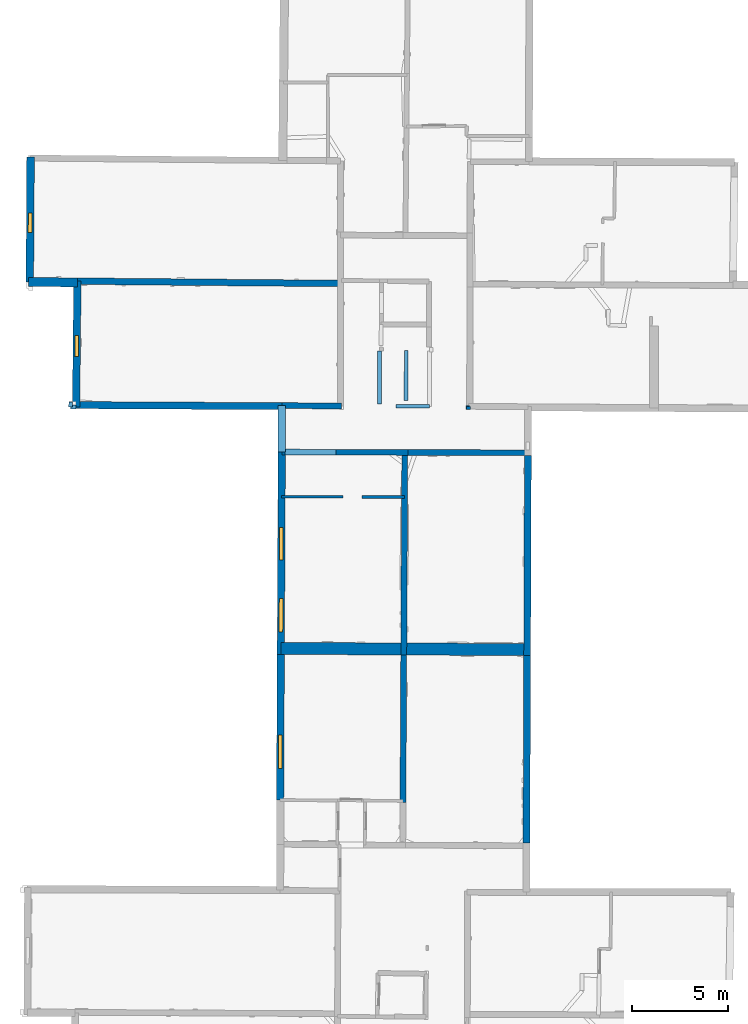
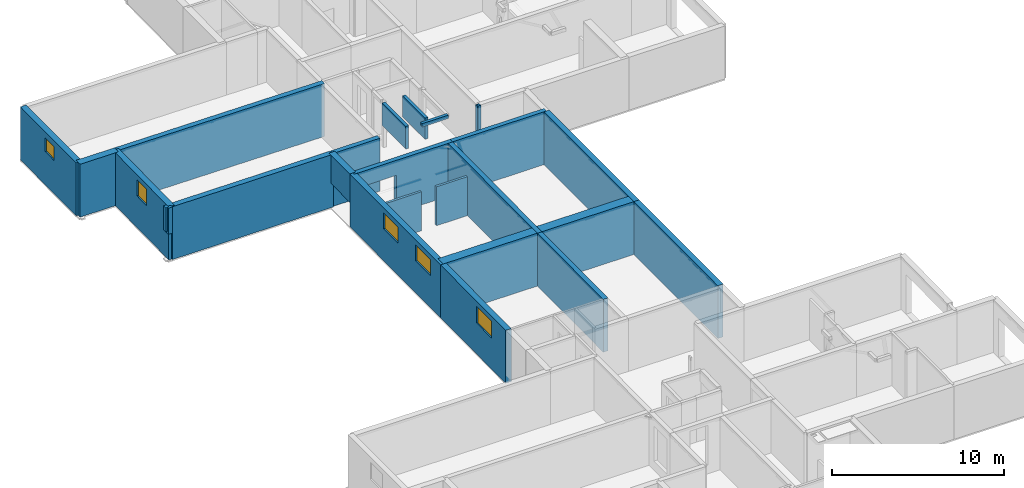
# One storey, part 5 of 12: 26 walls, 5 windows, 6 openings.
"""IFC2X3 building model written with IfcOpenShell, lengths in metres."""

from ifc_helpers import new_model, entity, si_unit, converted_unit, derived_unit, direction, frame, frame_2d, origin, origin_2d_with_axis, place, context, subcontext, project, spatial, polyline, rectangle, outline, extrude, source, transform, mapped, material, layer, layer_set, layer_usage, type_object, type_shapes, element, fill, save


model = new_model("IFC2X3")

# Units and contexts
model_context = context("Model", 3, precision=1e-05, world=origin(), true_north=direction((0.0, 1.0)))
body_context = subcontext(model_context, "Body", "Model", "MODEL_VIEW")
ifc_project = project(units=[si_unit("LENGTHUNIT", "METRE"), si_unit("AREAUNIT", "SQUARE_METRE"), si_unit("VOLUMEUNIT", "CUBIC_METRE"), converted_unit("PLANEANGLEUNIT", "DEGREE", entity("IfcRatioMeasure", 0.0174532925199433), si_unit("PLANEANGLEUNIT", "RADIAN"), dimensions=[0, 0, 0, 0, 0, 0, 0]), si_unit("MASSUNIT", "GRAM", prefix="KILO"), derived_unit("MASSDENSITYUNIT", [(si_unit("MASSUNIT", "GRAM", prefix="KILO"), 1), (si_unit("LENGTHUNIT", "METRE"), -3)]), derived_unit("MOMENTOFINERTIAUNIT", [(si_unit("LENGTHUNIT", "METRE"), 4)]), si_unit("TIMEUNIT", "SECOND"), si_unit("FREQUENCYUNIT", "HERTZ"), si_unit("THERMODYNAMICTEMPERATUREUNIT", "DEGREE_CELSIUS"), derived_unit("THERMALTRANSMITTANCEUNIT", [(si_unit("MASSUNIT", "GRAM", prefix="KILO"), 1), (si_unit("THERMODYNAMICTEMPERATUREUNIT", "KELVIN"), -1), (si_unit("TIMEUNIT", "SECOND"), -3)]), derived_unit("VOLUMETRICFLOWRATEUNIT", [(si_unit("LENGTHUNIT", "METRE"), 3), (si_unit("TIMEUNIT", "SECOND"), -1)]), si_unit("ELECTRICCURRENTUNIT", "AMPERE"), si_unit("ELECTRICVOLTAGEUNIT", "VOLT"), si_unit("POWERUNIT", "WATT"), si_unit("FORCEUNIT", "NEWTON", prefix="KILO"), si_unit("ILLUMINANCEUNIT", "LUX"), si_unit("LUMINOUSFLUXUNIT", "LUMEN"), si_unit("LUMINOUSINTENSITYUNIT", "CANDELA"), derived_unit("USERDEFINED", [(si_unit("MASSUNIT", "GRAM", prefix="KILO"), -1), (si_unit("LENGTHUNIT", "METRE"), -2), (si_unit("TIMEUNIT", "SECOND"), 3), (si_unit("LUMINOUSFLUXUNIT", "LUMEN"), 1)]), derived_unit("LINEARVELOCITYUNIT", [(si_unit("LENGTHUNIT", "METRE"), 1), (si_unit("TIMEUNIT", "SECOND"), -1)]), si_unit("PRESSUREUNIT", "PASCAL"), derived_unit("USERDEFINED", [(si_unit("LENGTHUNIT", "METRE"), -2), (si_unit("MASSUNIT", "GRAM", prefix="KILO"), 1), (si_unit("TIMEUNIT", "SECOND"), -2)]), derived_unit("LINEARFORCEUNIT", [(si_unit("MASSUNIT", "GRAM", prefix="KILO"), 1), (si_unit("LENGTHUNIT", "METRE"), 1), (si_unit("TIMEUNIT", "SECOND"), -2), (si_unit("LENGTHUNIT", "METRE"), -1)]), derived_unit("PLANARFORCEUNIT", [(si_unit("MASSUNIT", "GRAM", prefix="KILO"), 1), (si_unit("LENGTHUNIT", "METRE"), 1), (si_unit("TIMEUNIT", "SECOND"), -2), (si_unit("LENGTHUNIT", "METRE"), -2)])], contexts=[model_context])

# Site, building, storey
placement_1 = place(None, origin())
site = spatial("IfcSite", under=ifc_project, at=placement_1, CompositionType="ELEMENT")
building = spatial("IfcBuilding", under=site, at=placement_1, CompositionType="ELEMENT")
storey_placement = place(placement_1, frame((0.0, 0.0, -1.46125340461731)))
storey = spatial("IfcBuildingStorey", under=building, at=storey_placement, Name="Level 1", CompositionType="ELEMENT", Elevation=-1.46125340461731)

# Walls
ifc_material_1 = material(Name="Default wall")
ifc_layer_1 = layer(ifc_material_1, 0.2)
ifc_layer_set_1 = layer_set([ifc_layer_1], Name="wall_thickness_0.2000")
ifc_layer_usage_1 = layer_usage(ifc_layer_set_1, "AXIS2", "POSITIVE", -0.1)
wall_type_1 = type_object("IfcWallType", Name="wall_thickness_0.2000", PredefinedType="STANDARD", material=ifc_layer_set_1)
placement_2 = place(placement_1, frame((0.0, 0.0, -0.920999705791473)))
wall_1_placement = place(placement_2, frame((9.65902218523325, 51.2246109582655, 0.0), z_axis=(0.0, 0.0, 1.0), x_axis=(-0.00577955081336576, -0.999983298256724, 0.0)))
element("IfcWallStandardCase", 1, at=wall_1_placement, inside=storey, type_object=wall_type_1, material=ifc_layer_usage_1, Name="Wall:556", ObjectType="Wall", context=body_context, shape_type="SweptSolid", body=[
    extrude(outline(polyline([(0.165503405064523, -0.1), (0.165503405064523, 0.1), (0.0, 0.1), (0.0, -0.1), (0.165503405064523, -0.1)])), origin(), (0.0, 0.0, 1.0), 3.20173248052597),
])
placement_3 = place(placement_1, frame((0.0, 0.0, 0.434999942779541)))
wall_2_placement = place(placement_3, frame((-11.1547365528179, 51.1857922861533, 0.0), z_axis=(0.0, 0.0, 1.0), x_axis=(0.999997478921634, -0.00224547330765514, 0.0)))
element("IfcWallStandardCase", 2, at=wall_2_placement, inside=storey, type_object=wall_type_1, material=ifc_layer_usage_1, Name="Wall:610", ObjectType="Wall", context=body_context, shape_type="SweptSolid", body=[
    extrude(outline(polyline([(0.285404924850447, -0.1), (0.285404924850447, 0.1), (0.0, 0.1), (0.0, -0.1), (0.285404924850447, -0.1)])), origin(), (0.0, 0.0, 1.0), 1.84573283195496),
])
placement_4 = place(placement_1, frame((0.0, 0.0, 0.585000038146973)))
wall_3_placement = place(placement_4, frame((-11.1531351063067, 51.4586170862274, 0.0), z_axis=(0.0, 0.0, 1.0), x_axis=(-0.00586539127443417, -0.999982798444652, 0.0)))
element("IfcWallStandardCase", 3, at=wall_3_placement, inside=storey, type_object=wall_type_1, material=ifc_layer_usage_1, Name="Wall:613", ObjectType="Wall", context=body_context, shape_type="SweptSolid", body=[
    extrude(outline(polyline([(0.272831841569523, -0.1), (0.272831841569523, 0.1), (0.0, 0.1), (0.0, -0.1), (0.272831841569523, -0.1)])), origin(), (0.0, 0.0, 1.0), 1.69573273658752),
])
placement_5 = place(placement_1, frame((0.0, 0.0, 0.677000045776367)))
wall_4_placement = place(placement_5, frame((5.01080191928014, 54.1198655657872, 0.0), z_axis=(0.0, 0.0, 1.0), x_axis=(-0.0037398859132314, -0.999993006602224, 0.0)))
element("IfcWallStandardCase", 4, at=wall_4_placement, inside=storey, type_object=wall_type_1, material=ifc_layer_usage_1, Name="Wall:633", ObjectType="Wall", context=body_context, shape_type="SweptSolid", body=[
    extrude(outline(polyline([(2.76000236453854, -0.1), (2.76000236453854, 0.1), (0.0, 0.1), (0.0, -0.1), (2.76000236453854, -0.1)])), origin(), (0.0, 0.0, 1.0), 1.60373272895813),
])
placement_6 = place(placement_1, frame((0.0, 0.0, -0.920999705791473)))
wall_5_placement = place(placement_6, frame((9.53376574996294, 51.1704418584124, 0.0), z_axis=(0.0, 0.0, 1.0), x_axis=(0.999996585717186, -0.00261315020066087, 0.0)))
element("IfcWallStandardCase", 5, at=wall_5_placement, inside=storey, type_object=wall_type_1, material=ifc_layer_usage_1, Name="Wall:643", ObjectType="Wall", context=body_context, shape_type="SweptSolid", body=[
    extrude(outline(polyline([(0.194154448603764, -0.1), (0.194154448603764, 0.1), (0.0, 0.1), (0.0, -0.1), (0.194154448603764, -0.1)])), origin(), (0.0, 0.0, 1.0), 3.20173248052597),
])
placement_7 = place(placement_1, frame((0.0, 0.0, 2.04199981689453)))
wall_6_placement = place(placement_7, frame((5.86626068319124, 51.2314821738163, 0.0), z_axis=(0.0, 0.0, 1.0), x_axis=(0.999997598365567, -0.00219163480024743, 0.0)))
element("IfcWallStandardCase", 6, at=wall_6_placement, inside=storey, type_object=wall_type_1, material=ifc_layer_usage_1, Name="Wall:667", ObjectType="Wall", context=body_context, shape_type="SweptSolid", body=[
    extrude(outline(polyline([(1.7597178759488, -0.1), (1.7597178759488, 0.1), (0.0, 0.1), (0.0, -0.1), (1.7597178759488, -0.1)])), origin(), (0.0, 0.0, 1.0), 0.238732957839966),
])
placement_8 = place(placement_1, frame((0.0, 0.0, 0.782000541687012)))
wall_7_placement = place(placement_8, frame((6.40814079165082, 54.1460828912394, 0.0), z_axis=(0.0, 0.0, 1.0), x_axis=(-0.00428186551426408, -0.99999083277184, 0.0)))
element("IfcWallStandardCase", 7, at=wall_7_placement, inside=storey, type_object=wall_type_1, material=ifc_layer_usage_1, Name="Wall:674", ObjectType="Wall", context=body_context, shape_type="SweptSolid", body=[
    extrude(outline(polyline([(2.61500276261017, -0.1), (2.61500276261017, 0.1), (0.0, 0.1), (0.0, -0.1), (2.61500276261017, -0.1)])), origin(), (0.0, 0.0, 1.0), 1.49873223304749),
])

# Wall, openings, windows
ifc_layer_2 = layer(ifc_material_1, 0.379999995231628)
ifc_layer_set_2 = layer_set([ifc_layer_2], Name="wall_thickness_0.3800")
ifc_layer_usage_2 = layer_usage(ifc_layer_set_2, "AXIS2", "POSITIVE", -0.189999997615814)
wall_type_2 = type_object("IfcWallType", Name="wall_thickness_0.3800", PredefinedType="STANDARD", material=ifc_layer_set_2)
wall_8_placement = place(storey_placement, frame((-0.104662263932615, 48.8317897407372, 0.0), z_axis=(0.0, 0.0, 1.0), x_axis=(-0.0048725705329283, -0.99998812895774, 0.0)))
wall_8 = element("IfcWallStandardCase", 8, at=wall_8_placement, inside=storey, type_object=wall_type_2, material=ifc_layer_usage_2, Name="Wall:513", ObjectType="Wall", context=body_context, shape_type="SweptSolid", body=[
    extrude(outline(polyline([(10.5898588364411, -0.189999997615814), (10.5898588364411, 0.189999997615814), (0.0, 0.189999997615814), (0.0, -0.189999997615814), (10.5898588364411, -0.189999997615814)])), origin(), (0.0, 0.0, 1.0), 3.74198617935181),
])
opening_1_placement = place(wall_8_placement, frame((3.94140726197055, -0.189999997615814, 2.25025391578674)))
opening_1 = element("IfcOpeningElement", 9, at=opening_1_placement, cuts=wall_8, Name="Opening : 1705 x 1135 : 403", ObjectType="Opening", context=body_context, shape_type="SweptSolid", body=[
    extrude(rectangle(XDim=1.705, YDim=1.135, at=frame_2d((0.5675, 0.8525), x_axis=(0.0, 1.0))), frame((0.0, 0.0, 0.0), z_axis=(0.0, 1.0, 0.0), x_axis=(0.0, 0.0, 1.0)), (0.0, 0.0, 1.0), 0.379999995231628),
])
opening_2_placement = place(wall_8_placement, frame((7.67140530681995, -0.189999997615814, 2.2752537727356)))
opening_2 = element("IfcOpeningElement", 10, at=opening_2_placement, cuts=wall_8, Name="Opening : 1750 x 1110 : 404", ObjectType="Opening", context=body_context, shape_type="SweptSolid", body=[
    extrude(rectangle(XDim=1.75, YDim=1.11, at=frame_2d((0.555, 0.875), x_axis=(0.0, 1.0))), frame((0.0, 0.0, 0.0), z_axis=(0.0, 1.0, 0.0), x_axis=(0.0, 0.0, 1.0)), (0.0, 0.0, 1.0), 0.379999995231628),
])
ifc_material_2 = material(Name="Window Default")
window_style_1 = type_object("IfcWindowStyle", Name="Window : 1705 x 1135mm", ConstructionType="NOTDEFINED", OperationType="NOTDEFINED", ParameterTakesPrecedence=False, Sizeable=False, material=ifc_material_2)
shared_shape_1 = source(origin(), body_context, "Body", "SweptSolid", [
    extrude(rectangle(XDim=0.189999997615814, YDim=1.705, at=origin_2d_with_axis()), frame((0.8525, 0.189999997615814, 0.0), z_axis=(0.0, 0.0, 1.0), x_axis=(0.0, 1.0, 0.0)), (0.0, 0.0, 1.0), 1.135),
])
type_shapes(window_style_1, [shared_shape_1])
window_1_placement = place(opening_1_placement, origin())
window_1 = element("IfcWindow", 11, at=window_1_placement, inside=storey, type_object=window_style_1, Name="Window : 1705 x 1135mm : 225", ObjectType="Window : 1705 x 1135mm", OverallHeight=1.135, OverallWidth=1.705, context=body_context, shape_type="MappedRepresentation", body=[
    mapped(shared_shape_1, transform((0.0, 0.0, 0.0), scale=1.0)),
])
fill(opening_1, window_1)
window_style_2 = type_object("IfcWindowStyle", Name="Window : 1750 x 1110mm", ConstructionType="NOTDEFINED", OperationType="NOTDEFINED", ParameterTakesPrecedence=False, Sizeable=False, material=ifc_material_2)
shared_shape_2 = source(origin(), body_context, "Body", "SweptSolid", [
    extrude(rectangle(XDim=0.189999997615814, YDim=1.75, at=origin_2d_with_axis()), frame((0.875, 0.189999997615814, 0.0), z_axis=(0.0, 0.0, 1.0), x_axis=(0.0, 1.0, 0.0)), (0.0, 0.0, 1.0), 1.11),
])
type_shapes(window_style_2, [shared_shape_2])
window_2_placement = place(opening_2_placement, origin())
window_2 = element("IfcWindow", 12, at=window_2_placement, inside=storey, type_object=window_style_2, Name="Window : 1750 x 1110mm : 226", ObjectType="Window : 1750 x 1110mm", OverallHeight=1.11, OverallWidth=1.75, context=body_context, shape_type="MappedRepresentation", body=[
    mapped(shared_shape_2, transform((0.0, 0.0, 0.0), scale=1.0)),
])
fill(opening_2, window_2)

# Wall, opening, window
wall_9_placement = place(storey_placement, frame((-0.156262098046928, 38.2420566169579, 0.0), z_axis=(0.0, 0.0, 1.0), x_axis=(-0.00487257249916038, -0.999988128948159, 0.0)))
wall_9 = element("IfcWallStandardCase", 13, at=wall_9_placement, inside=storey, type_object=wall_type_2, material=ifc_layer_usage_2, Name="Wall:514", ObjectType="Wall", context=body_context, shape_type="SweptSolid", body=[
    extrude(outline(polyline([(7.62287796716546, -0.189999997615814), (7.62287796716546, 0.189999997615814), (0.0, 0.189999997615814), (0.0, -0.189999997615814), (7.62287796716546, -0.189999997615814)])), origin(), (0.0, 0.0, 1.0), 3.74198617935181),
])
opening_3_placement = place(wall_9_placement, frame((4.22255378760456, -0.189999997615814, 2.19425362348557)))
opening_3 = element("IfcOpeningElement", 14, at=opening_3_placement, cuts=wall_9, Name="Opening : 1745 x 1195 : 405", ObjectType="Opening", context=body_context, shape_type="SweptSolid", body=[
    extrude(rectangle(XDim=1.745, YDim=1.195, at=frame_2d((0.5975, 0.8725), x_axis=(0.0, 1.0))), frame((0.0, 0.0, 0.0), z_axis=(0.0, 1.0, 0.0), x_axis=(0.0, 0.0, 1.0)), (0.0, 0.0, 1.0), 0.379999995231628),
])
window_style_3 = type_object("IfcWindowStyle", Name="Window : 1745 x 1195mm", ConstructionType="NOTDEFINED", OperationType="NOTDEFINED", ParameterTakesPrecedence=False, Sizeable=False, material=ifc_material_2)
shared_shape_3 = source(origin(), body_context, "Body", "SweptSolid", [
    extrude(rectangle(XDim=0.189999997615814, YDim=1.745, at=origin_2d_with_axis()), frame((0.8725, 0.189999997615814, 0.0), z_axis=(0.0, 0.0, 1.0), x_axis=(0.0, 1.0, 0.0)), (0.0, 0.0, 1.0), 1.195),
])
type_shapes(window_style_3, [shared_shape_3])
window_3_placement = place(opening_3_placement, origin())
window_3 = element("IfcWindow", 15, at=window_3_placement, inside=storey, type_object=window_style_3, Name="Window : 1745 x 1195mm : 227", ObjectType="Window : 1745 x 1195mm", OverallHeight=1.195, OverallWidth=1.745, context=body_context, shape_type="MappedRepresentation", body=[
    mapped(shared_shape_3, transform((0.0, 0.0, 0.0), scale=1.0)),
])
fill(opening_3, window_3)

# Walls
ifc_layer_3 = layer(ifc_material_1, 0.340000003576279)
ifc_layer_set_3 = layer_set([ifc_layer_3], Name="wall_thickness_0.3400")
ifc_layer_usage_3 = layer_usage(ifc_layer_set_3, "AXIS2", "POSITIVE", -0.170000001788139)
wall_type_3 = type_object("IfcWallType", Name="wall_thickness_0.3400", PredefinedType="STANDARD", material=ifc_layer_set_3)
wall_10_placement = place(storey_placement, frame((-10.8028742730837, 57.7752963277272, 0.0), z_axis=(0.0, 0.0, 1.0), x_axis=(0.999960486772033, -0.00888959473982302, 0.0)))
element("IfcWallStandardCase", 16, at=wall_10_placement, inside=storey, type_object=wall_type_3, material=ifc_layer_usage_3, Name="Wall:606", ObjectType="Wall", context=body_context, shape_type="SweptSolid", body=[
    extrude(outline(polyline([(13.8133524164357, -0.170000001788139), (13.8133524164357, 0.170000001788139), (0.0, 0.170000001788139), (0.0, -0.170000001788139), (13.8133524164357, -0.170000001788139)])), origin(), (0.0, 0.0, 1.0), 3.74198617935181),
])
ifc_layer_4 = layer(ifc_material_1, 0.370000004768372)
ifc_layer_set_4 = layer_set([ifc_layer_4], Name="wall_thickness_0.3700")
ifc_layer_usage_4 = layer_usage(ifc_layer_set_4, "AXIS2", "POSITIVE", -0.185000002384186)
wall_type_4 = type_object("IfcWallType", Name="wall_thickness_0.3700", PredefinedType="STANDARD", material=ifc_layer_set_4)
wall_11_placement = place(storey_placement, frame((-10.8682760640818, 51.2898943262856, 0.0), z_axis=(0.0, 0.0, 1.0), x_axis=(0.999985588519995, -0.00536868254972591, 0.0)))
element("IfcWallStandardCase", 17, at=wall_11_placement, inside=storey, type_object=wall_type_4, material=ifc_layer_usage_4, Name="Wall:524", ObjectType="Wall", context=body_context, shape_type="SweptSolid", body=[
    extrude(outline(polyline([(10.7676179077179, -0.185000002384186), (10.7676179077179, 0.185000002384186), (0.0, 0.185000002384186), (0.0, -0.185000002384186), (10.7676179077179, -0.185000002384186)])), origin(), (0.0, 0.0, 1.0), 3.74198617935181),
])
ifc_layer_5 = layer(ifc_material_1, 0.389999985694885)
ifc_layer_set_5 = layer_set([ifc_layer_5], Name="wall_thickness_0.3900")
ifc_layer_usage_5 = layer_usage(ifc_layer_set_5, "AXIS2", "POSITIVE", -0.194999992847443)
wall_type_5 = type_object("IfcWallType", Name="wall_thickness_0.3900", PredefinedType="STANDARD", material=ifc_layer_set_5)
placement_9 = place(placement_1, frame((0.0, 0.0, 0.277000427246094)))
wall_12_placement = place(placement_9, frame((-0.100695590865515, 51.2620790462312, 0.0), z_axis=(0.0, 0.0, 1.0), x_axis=(-0.0039232591383254, -0.999992303989253, 0.0)))
element("IfcWallStandardCase", 18, at=wall_12_placement, inside=storey, type_object=wall_type_5, material=ifc_layer_usage_5, Name="Wall:573", ObjectType="Wall", context=body_context, shape_type="SweptSolid", body=[
    extrude(outline(polyline([(2.43029748167171, -0.194999992847443), (2.43029748167171, 0.194999992847443), (0.0, 0.194999992847443), (0.0, -0.194999992847443), (2.43029748167171, -0.194999992847443)])), origin(), (0.0, 0.0, 1.0), 2.0037323474884),
])

# Wall, opening, window
wall_13_placement = place(storey_placement, frame((-10.8028744857358, 57.7753084545291, 0.0), z_axis=(0.0, 0.0, 1.0), x_axis=(-0.010084022127229, -0.999949154956259, 0.0)))
wall_13 = element("IfcWallStandardCase", 19, at=wall_13_placement, inside=storey, type_object=wall_type_5, material=ifc_layer_usage_5, Name="Wall:678", ObjectType="Wall", context=body_context, shape_type="SweptSolid", body=[
    extrude(outline(polyline([(6.59049546390318, -0.194999992847443), (6.59049546390318, 0.194999992847443), (0.0, 0.194999992847443), (0.0, -0.194999992847443), (6.59049546390318, -0.194999992847443)])), origin(), (0.0, 0.0, 1.0), 3.74198617935181),
])
opening_4_placement = place(wall_13_placement, frame((2.83787081990509, -0.194999992847443, 2.24025297164917)))
opening_4 = element("IfcOpeningElement", 20, at=opening_4_placement, cuts=wall_13, Name="Opening : 1105 x 1150 : 431", ObjectType="Opening", context=body_context, shape_type="SweptSolid", body=[
    extrude(rectangle(XDim=1.105, YDim=1.15, at=frame_2d((0.575, 0.5525), x_axis=(0.0, 1.0))), frame((0.0, 0.0, 0.0), z_axis=(0.0, 1.0, 0.0), x_axis=(0.0, 0.0, 1.0)), (0.0, 0.0, 1.0), 0.389999985694885),
])
window_style_4 = type_object("IfcWindowStyle", Name="Window : 1105 x 1150mm", ConstructionType="NOTDEFINED", OperationType="NOTDEFINED", ParameterTakesPrecedence=False, Sizeable=False, material=ifc_material_2)
shared_shape_4 = source(origin(), body_context, "Body", "SweptSolid", [
    extrude(rectangle(XDim=0.194999992847443, YDim=1.105, at=origin_2d_with_axis()), frame((0.5525, 0.194999992847443, 0.0), z_axis=(0.0, 0.0, 1.0), x_axis=(0.0, 1.0, 0.0)), (0.0, 0.0, 1.0), 1.15),
])
type_shapes(window_style_4, [shared_shape_4])
window_4_placement = place(opening_4_placement, origin())
window_4 = element("IfcWindow", 21, at=window_4_placement, inside=storey, type_object=window_style_4, Name="Window : 1105 x 1150mm : 234", ObjectType="Window : 1105 x 1150mm", OverallHeight=1.15, OverallWidth=1.105, context=body_context, shape_type="MappedRepresentation", body=[
    mapped(shared_shape_4, transform((0.0, 0.0, 0.0), scale=1.0)),
])
fill(opening_4, window_4)

# Walls
ifc_layer_6 = layer(ifc_material_1, 0.360000014305115)
ifc_layer_set_6 = layer_set([ifc_layer_6], Name="wall_thickness_0.3600")
ifc_layer_usage_6 = layer_usage(ifc_layer_set_6, "AXIS2", "POSITIVE", -0.180000007152557)
wall_type_6 = type_object("IfcWallType", Name="wall_thickness_0.3600", PredefinedType="STANDARD", material=ifc_layer_set_6)
wall_14_placement = place(storey_placement, frame((12.7742391255006, 48.6461178561589, 0.0), z_axis=(0.0, 0.0, 1.0), x_axis=(-0.00364340932803328, -0.999993362762208, 0.0)))
element("IfcWallStandardCase", 22, at=wall_14_placement, inside=storey, type_object=wall_type_6, material=ifc_layer_usage_6, Name="Wall:588", ObjectType="Wall", context=body_context, shape_type="SweptSolid", body=[
    extrude(outline(polyline([(10.4672516330619, -0.180000007152557), (10.4672516330619, 0.180000007152557), (0.0, 0.180000007152557), (0.0, -0.180000007152557), (10.4672516330619, -0.180000007152557)])), origin(), (0.0, 0.0, 1.0), 3.74198617935181),
])
wall_15_placement = place(storey_placement, frame((12.7361026432618, 38.1789356967351, 0.0), z_axis=(0.0, 0.0, 1.0), x_axis=(-0.003643519624433, -0.999993362360344, 0.0)))
element("IfcWallStandardCase", 23, at=wall_15_placement, inside=storey, type_object=wall_type_6, material=ifc_layer_usage_6, Name="Wall:589", ObjectType="Wall", context=body_context, shape_type="SweptSolid", body=[
    extrude(outline(polyline([(9.79739016582283, -0.180000007152557), (9.79739016582283, 0.180000007152557), (0.0, 0.180000007152557), (0.0, -0.180000007152557), (9.79739016582283, -0.180000007152557)])), origin(), (0.0, 0.0, 1.0), 3.74198617935181),
])
ifc_layer_7 = layer(ifc_material_1, 0.150000005960464)
ifc_layer_set_7 = layer_set([ifc_layer_7], Name="wall_thickness_0.1500")
ifc_layer_usage_7 = layer_usage(ifc_layer_set_7, "AXIS2", "POSITIVE", -0.0750000029802322)
wall_type_7 = type_object("IfcWallType", Name="wall_thickness_0.1500", PredefinedType="STANDARD", material=ifc_layer_set_7)
wall_16_placement = place(storey_placement, frame((4.09984349934582, 46.4880920652875, 0.0), z_axis=(0.0, 0.0, 1.0), x_axis=(0.999989464009831, -0.00459041058422784, 0.0)))
element("IfcWallStandardCase", 24, at=wall_16_placement, inside=storey, type_object=wall_type_7, material=ifc_layer_usage_7, Name="Wall:554", ObjectType="Wall", context=body_context, shape_type="SweptSolid", body=[
    extrude(outline(polyline([(2.22047045830096, -0.0750000029802322), (2.22047045830096, 0.0750000029802322), (0.0, 0.0750000029802322), (0.0, -0.0750000029802322), (2.22047045830096, -0.0750000029802322)])), origin(), (0.0, 0.0, 1.0), 2.75525379180908),
])
wall_17_placement = place(storey_placement, frame((-0.116043128589695, 46.4961387546905, 0.0), z_axis=(0.0, 0.0, 1.0), x_axis=(0.999999843604715, -0.000559276806692586, 0.0)))
element("IfcWallStandardCase", 25, at=wall_17_placement, inside=storey, type_object=wall_type_7, material=ifc_layer_usage_7, Name="Wall:628", ObjectType="Wall", context=body_context, shape_type="SweptSolid", body=[
    extrude(outline(polyline([(3.21258166011695, -0.0750000029802322), (3.21258166011695, 0.0750000029802322), (0.0, 0.0750000029802322), (0.0, -0.0750000029802322), (3.21258166011695, -0.0750000029802322)])), origin(), (0.0, 0.0, 1.0), 2.75525379180908),
])

# Wall, opening, window
ifc_layer_8 = layer(ifc_material_1, 0.400000005960464)
ifc_layer_set_8 = layer_set([ifc_layer_8], Name="wall_thickness_0.4000")
ifc_layer_usage_8 = layer_usage(ifc_layer_set_8, "AXIS2", "POSITIVE", -0.200000002980232)
wall_type_8 = type_object("IfcWallType", Name="wall_thickness_0.4000", PredefinedType="STANDARD", material=ifc_layer_set_8)
wall_18_placement = place(storey_placement, frame((-13.2507438020781, 64.2644064731623, 0.0), z_axis=(0.0, 0.0, 1.0), x_axis=(-0.00638157018123186, -0.999979637573697, 0.0)))
wall_18 = element("IfcWallStandardCase", 26, at=wall_18_placement, inside=storey, type_object=wall_type_8, material=ifc_layer_usage_8, Name="Wall:578", ObjectType="Wall", context=body_context, shape_type="SweptSolid", body=[
    extrude(outline(polyline([(6.53210780204419, -0.200000002980232), (6.53210780204419, 0.200000002980232), (0.0, 0.200000002980232), (0.0, -0.200000002980232), (6.53210780204419, -0.200000002980232)])), origin(), (0.0, 0.0, 1.0), 3.74198617935181),
])
opening_5_placement = place(wall_18_placement, frame((2.92024070281559, -0.200000002980232, 2.3442530632019)))
opening_5 = element("IfcOpeningElement", 27, at=opening_5_placement, cuts=wall_18, Name="Opening : 1015 x 965 : 414", ObjectType="Opening", context=body_context, shape_type="SweptSolid", body=[
    extrude(rectangle(XDim=1.015, YDim=0.965, at=frame_2d((0.4825, 0.5075), x_axis=(0.0, 1.0))), frame((0.0, 0.0, 0.0), z_axis=(0.0, 1.0, 0.0), x_axis=(0.0, 0.0, 1.0)), (0.0, 0.0, 1.0), 0.400000005960464),
])
window_style_5 = type_object("IfcWindowStyle", Name="Window : 1015 x 965mm", ConstructionType="NOTDEFINED", OperationType="NOTDEFINED", ParameterTakesPrecedence=False, Sizeable=False, material=ifc_material_2)
shared_shape_5 = source(origin(), body_context, "Body", "SweptSolid", [
    extrude(rectangle(XDim=0.200000002980232, YDim=1.015, at=origin_2d_with_axis()), frame((0.5075, 0.200000002980232, 0.0), z_axis=(0.0, 0.0, 1.0), x_axis=(0.0, 1.0, 0.0)), (0.0, 0.0, 1.0), 0.965),
])
type_shapes(window_style_5, [shared_shape_5])
window_5_placement = place(opening_5_placement, origin())
window_5 = element("IfcWindow", 28, at=window_5_placement, inside=storey, type_object=window_style_5, Name="Window : 1015 x 965mm : 230", ObjectType="Window : 1015 x 965mm", OverallHeight=0.965, OverallWidth=1.015, context=body_context, shape_type="MappedRepresentation", body=[
    mapped(shared_shape_5, transform((0.0, 0.0, 0.0), scale=1.0)),
])
fill(opening_5, window_5)

# Wall, opening
ifc_layer_9 = layer(ifc_material_1, 0.300000011920929)
ifc_layer_set_9 = layer_set([ifc_layer_9], Name="wall_thickness_0.3000")
ifc_layer_usage_9 = layer_usage(ifc_layer_set_9, "AXIS2", "POSITIVE", -0.150000005960464)
wall_type_9 = type_object("IfcWallType", Name="wall_thickness_0.3000", PredefinedType="STANDARD", material=ifc_layer_set_9)
wall_19_placement = place(storey_placement, frame((-0.10466232194224, 48.8317850142052, 0.0), z_axis=(0.0, 0.0, 1.0), x_axis=(0.999996163310245, -0.0027700838956233, 0.0)))
wall_19 = element("IfcWallStandardCase", 29, at=wall_19_placement, inside=storey, type_object=wall_type_9, material=ifc_layer_usage_9, Name="Wall:528", ObjectType="Wall", context=body_context, shape_type="SweptSolid", body=[
    extrude(outline(polyline([(6.59220316012773, -0.150000005960464), (6.59220316012773, 0.150000005960464), (0.0, 0.150000005960464), (0.0, -0.150000005960464), (6.59220316012773, -0.150000005960464)])), origin(), (0.0, 0.0, 1.0), 3.74198617935181),
])
opening_6_placement = place(wall_19_placement, frame((0.167748234154497, -0.150000005960464, 0.56225323677063)))
element("IfcOpeningElement", 30, at=opening_6_placement, cuts=wall_19, Name="Opening : 2675 x 2120 : 408", ObjectType="Opening", context=body_context, shape_type="SweptSolid", body=[
    extrude(rectangle(XDim=2.675, YDim=2.12, at=frame_2d((1.06, 1.3375), x_axis=(0.0, 1.0))), frame((0.0, 0.0, 0.0), z_axis=(0.0, 1.0, 0.0), x_axis=(0.0, 0.0, 1.0)), (0.0, 0.0, 1.0), 0.300000011920929),
])

# Walls
wall_20_placement = place(storey_placement, frame((6.48751554594716, 48.8135240583946, 0.0), z_axis=(0.0, 0.0, 1.0), x_axis=(0.99999616429681, -0.00276972772456662, 0.0)))
element("IfcWallStandardCase", 31, at=wall_20_placement, inside=storey, type_object=wall_type_9, material=ifc_layer_usage_9, Name="Wall:529", ObjectType="Wall", context=body_context, shape_type="SweptSolid", body=[
    extrude(outline(polyline([(6.28729418531668, -0.150000005960464), (6.28729418531668, 0.150000005960464), (0.0, 0.150000005960464), (0.0, -0.150000005960464), (6.28729418531668, -0.150000005960464)])), origin(), (0.0, 0.0, 1.0), 3.74198617935181),
])
ifc_layer_10 = layer(ifc_material_1, 0.310000002384186)
ifc_layer_set_10 = layer_set([ifc_layer_10], Name="wall_thickness_0.3100")
ifc_layer_usage_10 = layer_usage(ifc_layer_set_10, "AXIS2", "POSITIVE", -0.155000001192093)
wall_type_10 = type_object("IfcWallType", Name="wall_thickness_0.3100", PredefinedType="STANDARD", material=ifc_layer_set_10)
wall_21_placement = place(storey_placement, frame((-0.100696211472623, 51.2620783437473, 0.0), z_axis=(0.0, 0.0, 1.0), x_axis=(0.999985599444319, -0.0053666473692066, 0.0)))
element("IfcWallStandardCase", 32, at=wall_21_placement, inside=storey, type_object=wall_type_10, material=ifc_layer_usage_10, Name="Wall:525", ObjectType="Wall", context=body_context, shape_type="SweptSolid", body=[
    extrude(outline(polyline([(3.11337281434007, -0.155000001192093), (3.11337281434007, 0.155000001192093), (0.0, 0.155000001192093), (0.0, -0.155000001192093), (3.11337281434007, -0.155000001192093)])), origin(), (0.0, 0.0, 1.0), 3.74198617935181),
])
wall_22_placement = place(storey_placement, frame((6.33251661755288, 48.8139597278861, 0.0), z_axis=(0.0, 0.0, 1.0), x_axis=(-0.00523376738085445, -0.999986303745708, 0.0)))
element("IfcWallStandardCase", 33, at=wall_22_placement, inside=storey, type_object=wall_type_10, material=ifc_layer_usage_10, Name="Wall:551", ObjectType="Wall", context=body_context, shape_type="SweptSolid", body=[
    extrude(outline(polyline([(10.6034930064569, -0.155000001192093), (10.6034930064569, 0.155000001192093), (0.0, 0.155000001192093), (0.0, -0.155000001192093), (10.6034930064569, -0.155000001192093)])), origin(), (0.0, 0.0, 1.0), 3.74198617935181),
])
wall_23_placement = place(storey_placement, frame((6.27702040173256, 38.2106119495658, 0.0), z_axis=(0.0, 0.0, 1.0), x_axis=(-0.00523372709750049, -0.999986303956544, 0.0)))
element("IfcWallStandardCase", 34, at=wall_23_placement, inside=storey, type_object=wall_type_10, material=ifc_layer_usage_10, Name="Wall:552", ObjectType="Wall", context=body_context, shape_type="SweptSolid", body=[
    extrude(outline(polyline([(7.70851011710517, -0.155000001192093), (7.70851011710517, 0.155000001192093), (0.0, 0.155000001192093), (0.0, -0.155000001192093), (7.70851011710517, -0.155000001192093)])), origin(), (0.0, 0.0, 1.0), 3.74198617935181),
])
ifc_layer_11 = layer(ifc_material_1, 0.629999995231628)
ifc_layer_set_11 = layer_set([ifc_layer_11], Name="wall_thickness_0.6300")
ifc_layer_usage_11 = layer_usage(ifc_layer_set_11, "AXIS2", "POSITIVE", -0.314999997615814)
wall_type_11 = type_object("IfcWallType", Name="wall_thickness_0.6300", PredefinedType="STANDARD", material=ifc_layer_set_11)
wall_24_placement = place(storey_placement, frame((-0.154728772766986, 38.557054022639, 0.0), z_axis=(0.0, 0.0, 1.0), x_axis=(0.999988011366212, -0.0048966441414422, 0.0)))
element("IfcWallStandardCase", 35, at=wall_24_placement, inside=storey, type_object=wall_type_11, material=ifc_layer_usage_11, Name="Wall:531", ObjectType="Wall", context=body_context, shape_type="SweptSolid", body=[
    extrude(outline(polyline([(6.58836824639842, -0.314999997615814), (6.58836824639842, 0.314999997615814), (0.0, 0.314999997615814), (0.0, -0.314999997615814), (6.58836824639842, -0.314999997615814)])), origin(), (0.0, 0.0, 1.0), 3.74198617935181),
])
wall_25_placement = place(storey_placement, frame((6.43356048809727, 38.5247931278636, 0.0), z_axis=(0.0, 0.0, 1.0), x_axis=(0.999988013381838, -0.00489623249502372, 0.0)))
element("IfcWallStandardCase", 36, at=wall_25_placement, inside=storey, type_object=wall_type_11, material=ifc_layer_usage_11, Name="Wall:532", ObjectType="Wall", context=body_context, shape_type="SweptSolid", body=[
    extrude(outline(polyline([(6.30376837855253, -0.314999997615814), (6.30376837855253, 0.314999997615814), (0.0, 0.314999997615814), (0.0, -0.314999997615814), (6.30376837855253, -0.314999997615814)])), origin(), (0.0, 0.0, 1.0), 3.74198617935181),
])
ifc_layer_12 = layer(ifc_material_1, 0.469999998807907)
ifc_layer_set_12 = layer_set([ifc_layer_12], Name="wall_thickness_0.4700")
ifc_layer_usage_12 = layer_usage(ifc_layer_set_12, "AXIS2", "POSITIVE", -0.234999999403954)
wall_type_12 = type_object("IfcWallType", Name="wall_thickness_0.4700", PredefinedType="STANDARD", material=ifc_layer_set_12)
wall_26_placement = place(storey_placement, frame((-13.3655991828315, 57.7330764553606, 0.0), z_axis=(0.0, 0.0, 1.0), x_axis=(0.999960496932694, -0.00888845172790166, 0.0)))
element("IfcWallStandardCase", 37, at=wall_26_placement, inside=storey, type_object=wall_type_12, material=ifc_layer_usage_12, Name="Wall:605", ObjectType="Wall", context=body_context, shape_type="SweptSolid", body=[
    extrude(outline(polyline([(2.56217206021296, -0.234999999403954), (2.56217206021296, 0.234999999403954), (0.0, 0.234999999403954), (0.0, -0.234999999403954), (2.56217206021296, -0.234999999403954)])), origin(), (0.0, 0.0, 1.0), 3.74198617935181),
])

save(model, "model.ifc")
